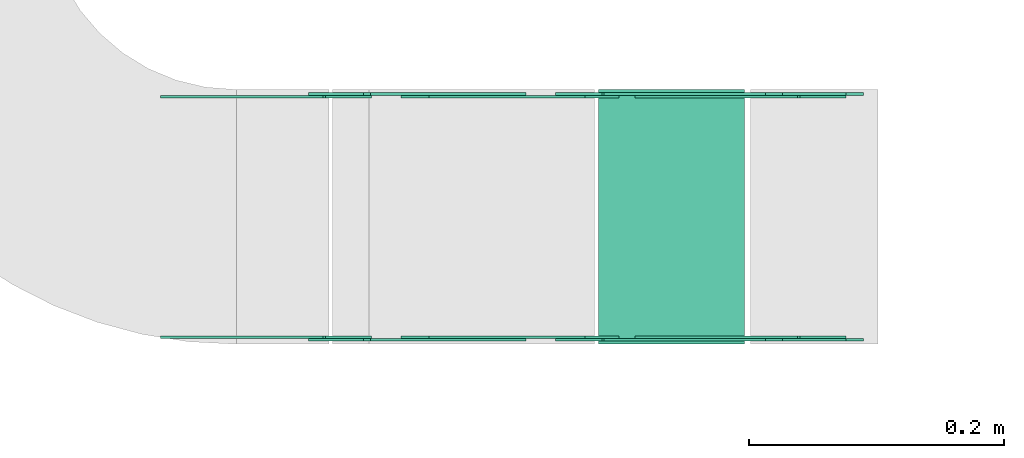
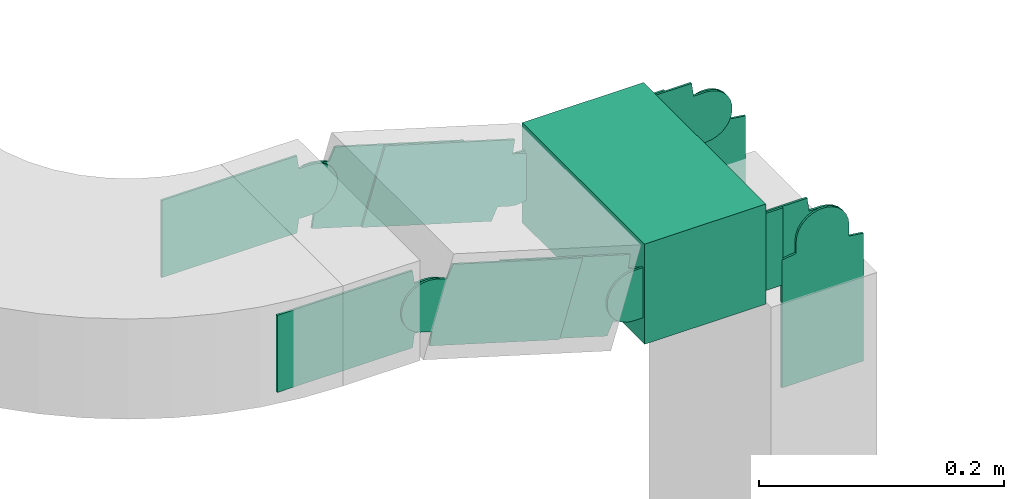
# One storey, part 21 of 38: 12 flow fittings, 1 flow segment.
"""IFC2X3 building model written with IfcOpenShell, lengths in millimetres."""

from ifc_helpers import new_model, entity, si_unit, converted_unit, derived_unit, direction, frame, frame_2d, origin, place, context, subcontext, project, spatial, polyline, circle_curve, parameter, trimmed, segment, composite_curve, rectangle, outline, extrude, source, transform, mapped, material, type_object, type_shapes, element, save


model = new_model("IFC2X3")

# Units and contexts
model_context = context("Model", 3, precision=0.01, world=origin(), true_north=direction((6.12303176911189e-17, 1.0)))
body_context = subcontext(model_context, "Body", "Model", "MODEL_VIEW")
ifc_project = project(units=[si_unit("LENGTHUNIT", "METRE", prefix="MILLI"), si_unit("AREAUNIT", "SQUARE_METRE"), si_unit("VOLUMEUNIT", "CUBIC_METRE"), converted_unit("PLANEANGLEUNIT", "DEGREE", entity("IfcRatioMeasure", 0.0174532925199433), si_unit("PLANEANGLEUNIT", "RADIAN"), dimensions=[0, 0, 0, 0, 0, 0, 0]), si_unit("MASSUNIT", "GRAM", prefix="KILO"), derived_unit("MASSDENSITYUNIT", [(si_unit("MASSUNIT", "GRAM", prefix="KILO"), 1), (si_unit("LENGTHUNIT", "METRE"), -3)]), derived_unit("MOMENTOFINERTIAUNIT", [(si_unit("LENGTHUNIT", "METRE"), 4)]), si_unit("TIMEUNIT", "SECOND"), si_unit("FREQUENCYUNIT", "HERTZ"), si_unit("THERMODYNAMICTEMPERATUREUNIT", "DEGREE_CELSIUS"), derived_unit("THERMALTRANSMITTANCEUNIT", [(si_unit("MASSUNIT", "GRAM", prefix="KILO"), 1), (si_unit("THERMODYNAMICTEMPERATUREUNIT", "KELVIN"), -1), (si_unit("TIMEUNIT", "SECOND"), -3)]), derived_unit("VOLUMETRICFLOWRATEUNIT", [(si_unit("LENGTHUNIT", "METRE"), 3), (si_unit("TIMEUNIT", "SECOND"), -1)]), derived_unit("MASSFLOWRATEUNIT", [(si_unit("MASSUNIT", "GRAM", prefix="KILO"), 1), (si_unit("TIMEUNIT", "SECOND"), -1)]), derived_unit("ROTATIONALFREQUENCYUNIT", [(si_unit("TIMEUNIT", "SECOND"), -1)]), si_unit("ELECTRICCURRENTUNIT", "AMPERE"), si_unit("ELECTRICVOLTAGEUNIT", "VOLT"), si_unit("POWERUNIT", "WATT"), si_unit("FORCEUNIT", "NEWTON", prefix="KILO"), si_unit("ILLUMINANCEUNIT", "LUX"), si_unit("LUMINOUSFLUXUNIT", "LUMEN"), si_unit("LUMINOUSINTENSITYUNIT", "CANDELA"), derived_unit("USERDEFINED", [(si_unit("MASSUNIT", "GRAM", prefix="KILO"), -1), (si_unit("LENGTHUNIT", "METRE"), -2), (si_unit("TIMEUNIT", "SECOND"), 3), (si_unit("LUMINOUSFLUXUNIT", "LUMEN"), 1)]), derived_unit("LINEARVELOCITYUNIT", [(si_unit("LENGTHUNIT", "METRE"), 1), (si_unit("TIMEUNIT", "SECOND"), -1)]), si_unit("PRESSUREUNIT", "PASCAL"), derived_unit("USERDEFINED", [(si_unit("LENGTHUNIT", "METRE"), -2), (si_unit("MASSUNIT", "GRAM", prefix="KILO"), 1), (si_unit("TIMEUNIT", "SECOND"), -2)]), derived_unit("LINEARFORCEUNIT", [(si_unit("MASSUNIT", "GRAM", prefix="KILO"), 1), (si_unit("LENGTHUNIT", "METRE"), 1), (si_unit("TIMEUNIT", "SECOND"), -2), (si_unit("LENGTHUNIT", "METRE"), -1)]), derived_unit("PLANARFORCEUNIT", [(si_unit("MASSUNIT", "GRAM", prefix="KILO"), 1), (si_unit("LENGTHUNIT", "METRE"), 1), (si_unit("TIMEUNIT", "SECOND"), -2), (si_unit("LENGTHUNIT", "METRE"), -2)])], contexts=[model_context])

# Site, building, storey
site_placement = place(None, frame((0.0, -0.00077364408347762, 0.0)))
site = spatial("IfcSite", under=ifc_project, at=site_placement, CompositionType="ELEMENT")
building_placement = place(site_placement, origin())
building = spatial("IfcBuilding", under=site, at=building_placement, CompositionType="ELEMENT")
storey_placement = place(building_placement, frame((0.0, 0.0, 4200.0)))
storey = spatial("IfcBuildingStorey", under=building, at=storey_placement, CompositionType="ELEMENT", Elevation=4200.0)

# Flow segment
cable_carrier_segment_type = type_object("IfcCableCarrierSegmentType", PredefinedType="CABLETRAYSEGMENT")
flow_segment_placement = place(storey_placement, frame((27566.6852011404, 7525.00077377346, 2871.96103583828)))
element("IfcFlowSegment", 1, at=flow_segment_placement, inside=storey, type_object=cable_carrier_segment_type, context=body_context, shape_type="SweptSolid", body=[
    extrude(rectangle(XDim=114.530349824433, YDim=200.0, at=frame_2d((2.16360263038951e-12, 0.0), x_axis=(1.0, 0.0))), frame((57.2651749122099, 100.0, 0.0)), (0.0, 0.0, 1.0), 99.9999999999989),
])

# Flow fittings
ifc_material = material(Name="G")
cable_carrier_fitting_type_1 = type_object("IfcCableCarrierFittingType", PredefinedType="NOTDEFINED", material=ifc_material)
shared_shape_1 = source(origin(), body_context, "Body", "SweptSolid", [
    extrude(outline(composite_curve([segment(trimmed(circle_curve(frame_2d((-41.4651162790697, 0.0), x_axis=(1.0, 0.0)), 25.0), [parameter(90.0000000000007)], [parameter(270.0)], True, "PARAMETER"), True, "CONTINUOUS"), segment(polyline([(-41.4651162790697, -25.0), (-29.9651162790697, -25.0)]), True, "CONTINUOUS"), segment(polyline([(-29.9651162790697, -25.0), (-28.1046511627907, -38.5)]), True, "CONTINUOUS"), segment(polyline([(-28.1046511627907, -38.5), (99.5348837209303, -38.5)]), True, "CONTINUOUS"), segment(polyline([(99.5348837209303, -38.5), (99.5348837209303, 38.5)]), True, "CONTINUOUS"), segment(polyline([(99.5348837209303, 38.5), (-28.1046511627907, 38.5)]), True, "CONTINUOUS"), segment(polyline([(-28.1046511627907, 38.5), (-29.9651162790697, 25.0)]), True, "CONTINUOUS"), segment(polyline([(-29.9651162790697, 25.0), (-41.46511627907, 25.0)]), True, "CONTINUOUS")], self_intersect=False)), frame((41.4651162790697, 0.0, 0.0), z_axis=(0.0, 0.0, -1.0), x_axis=(1.0, 0.0, 0.0)), (0.0, 0.0, -1.0), 2.0),
])
type_shapes(cable_carrier_fitting_type_1, [shared_shape_1])
for number, where, z_axis, x_axis in (
    (2, (27363.7155509645, 7720.46077378362, 2980.0), (0.0, 1.0, 0.0), (0.958072371883613, 0.0, -0.286526316825012)),
    (3, (27557.7833373836, 7529.5407737633, 2921.96103583827), (0.0, -1.0, 0.0), (1.0, 0.0, 0.0)),
    (4, (27736.2155509648, 7720.46077378362, 2921.96103583827), (0.0, 1.0, 0.0), (0.0, 0.0, -1.0)),
):
    element("IfcFlowFitting", number, at=place(storey_placement, frame(where, z_axis=z_axis, x_axis=x_axis)), inside=storey, type_object=cable_carrier_fitting_type_1, material=ifc_material, context=body_context, shape_type="MappedRepresentation", body=[
        mapped(shared_shape_1, transform((0.0, 0.0, 0.0), scale=1.0)),
    ])
cable_carrier_fitting_type_2 = type_object("IfcCableCarrierFittingType", PredefinedType="NOTDEFINED", material=ifc_material)
shared_shape_2 = source(origin(), body_context, "Body", "SweptSolid", [
    extrude(outline(composite_curve([segment(trimmed(circle_curve(frame_2d((-41.4651162790697, 0.0), x_axis=(1.0, 0.0)), 25.0), [parameter(90.0000000000007)], [parameter(270.0)], True, "PARAMETER"), True, "CONTINUOUS"), segment(polyline([(-41.4651162790697, -25.0), (-29.9651162790697, -25.0)]), True, "CONTINUOUS"), segment(polyline([(-29.9651162790697, -25.0), (-28.1046511627907, -38.5)]), True, "CONTINUOUS"), segment(polyline([(-28.1046511627907, -38.5), (99.5348837209303, -38.5)]), True, "CONTINUOUS"), segment(polyline([(99.5348837209303, -38.5), (99.5348837209303, 38.5)]), True, "CONTINUOUS"), segment(polyline([(99.5348837209303, 38.5), (-28.1046511627907, 38.5)]), True, "CONTINUOUS"), segment(polyline([(-28.1046511627907, 38.5), (-29.9651162790697, 25.0)]), True, "CONTINUOUS"), segment(polyline([(-29.9651162790697, 25.0), (-41.46511627907, 25.0)]), True, "CONTINUOUS")], self_intersect=False)), frame((41.4651162790697, 0.0, 0.0)), (0.0, 0.0, 1.0), 2.0),
])
type_shapes(cable_carrier_fitting_type_2, [shared_shape_2])
for number, where, z_axis, x_axis in (
    (5, (27363.7155509645, 7529.5407737633, 2980.0), (0.0, -1.0, 0.0), (0.958072371883613, 0.0, -0.286526316825012)),
    (6, (27557.7833373836, 7720.46077378362, 2921.96103583827), (0.0, 1.0, 0.0), (1.0, 0.0, 0.0)),
    (7, (27736.2155509648, 7529.5407737633, 2921.96103583827), (0.0, -1.0, 0.0), (0.0, 0.0, -1.0)),
):
    element("IfcFlowFitting", number, at=place(storey_placement, frame(where, z_axis=z_axis, x_axis=x_axis)), inside=storey, type_object=cable_carrier_fitting_type_2, material=ifc_material, context=body_context, shape_type="MappedRepresentation", body=[
        mapped(shared_shape_2, transform((0.0, 0.0, 0.0), scale=1.0)),
    ])
cable_carrier_fitting_type_3 = type_object("IfcCableCarrierFittingType", PredefinedType="NOTDEFINED", material=ifc_material)
shared_shape_3 = source(origin(), body_context, "Body", "SweptSolid", [
    extrude(outline(composite_curve([segment(trimmed(circle_curve(frame_2d((-41.4651162790697, 0.0), x_axis=(1.0, 0.0)), 25.0), [parameter(90.0000000000007)], [parameter(270.0)], True, "PARAMETER"), True, "CONTINUOUS"), segment(polyline([(-41.4651162790697, -25.0), (-29.9651162790697, -25.0)]), True, "CONTINUOUS"), segment(polyline([(-29.9651162790697, -25.0), (-28.1046511627907, -38.5)]), True, "CONTINUOUS"), segment(polyline([(-28.1046511627907, -38.5), (99.5348837209303, -38.5)]), True, "CONTINUOUS"), segment(polyline([(99.5348837209303, -38.5), (99.5348837209303, 38.5)]), True, "CONTINUOUS"), segment(polyline([(99.5348837209303, 38.5), (-28.1046511627907, 38.5)]), True, "CONTINUOUS"), segment(polyline([(-28.1046511627907, 38.5), (-29.9651162790697, 25.0)]), True, "CONTINUOUS"), segment(polyline([(-29.9651162790697, 25.0), (-41.46511627907, 25.0)]), True, "CONTINUOUS")], self_intersect=False)), frame((41.4651162790697, 0.0, 0.0), z_axis=(0.0, 0.0, -1.0), x_axis=(1.0, 0.0, 0.0)), (0.0, 0.0, -1.0), 2.0),
])
type_shapes(cable_carrier_fitting_type_3, [shared_shape_3])
for number, where, z_axis, x_axis in (
    (8, (27363.7155509645, 7531.5407737633, 2980.0), (0.0, -1.0, 0.0), (-1.0, 0.0, 0.0)),
    (9, (27557.7833373836, 7718.46077378361, 2921.96103583827), (0.0, 1.0, 0.0), (-0.958072371883606, 0.0, 0.286526316825037)),
    (10, (27736.2155509648, 7531.5407737633, 2921.96103583829), (0.0, -1.0, 0.0), (-1.0, 0.0, 0.0)),
):
    element("IfcFlowFitting", number, at=place(storey_placement, frame(where, z_axis=z_axis, x_axis=x_axis)), inside=storey, type_object=cable_carrier_fitting_type_3, material=ifc_material, context=body_context, shape_type="MappedRepresentation", body=[
        mapped(shared_shape_3, transform((0.0, 0.0, 0.0), scale=1.0)),
    ])
cable_carrier_fitting_type_4 = type_object("IfcCableCarrierFittingType", PredefinedType="NOTDEFINED", material=ifc_material)
shared_shape_4 = source(origin(), body_context, "Body", "SweptSolid", [
    extrude(outline(composite_curve([segment(trimmed(circle_curve(frame_2d((-41.4651162790697, 0.0), x_axis=(1.0, 0.0)), 25.0), [parameter(90.0000000000007)], [parameter(270.0)], True, "PARAMETER"), True, "CONTINUOUS"), segment(polyline([(-41.4651162790697, -25.0), (-29.9651162790697, -25.0)]), True, "CONTINUOUS"), segment(polyline([(-29.9651162790697, -25.0), (-28.1046511627907, -38.5)]), True, "CONTINUOUS"), segment(polyline([(-28.1046511627907, -38.5), (99.5348837209303, -38.5)]), True, "CONTINUOUS"), segment(polyline([(99.5348837209303, -38.5), (99.5348837209303, 38.5)]), True, "CONTINUOUS"), segment(polyline([(99.5348837209303, 38.5), (-28.1046511627907, 38.5)]), True, "CONTINUOUS"), segment(polyline([(-28.1046511627907, 38.5), (-29.9651162790697, 25.0)]), True, "CONTINUOUS"), segment(polyline([(-29.9651162790697, 25.0), (-41.46511627907, 25.0)]), True, "CONTINUOUS")], self_intersect=False)), frame((41.4651162790697, 0.0, 0.0)), (0.0, 0.0, 1.0), 2.0),
])
type_shapes(cable_carrier_fitting_type_4, [shared_shape_4])
for number, where, z_axis, x_axis in (
    (11, (27363.7155509645, 7718.46077378361, 2980.0), (0.0, 1.0, 0.0), (-1.0, 0.0, 0.0)),
    (12, (27557.7833373836, 7531.5407737633, 2921.96103583827), (0.0, -1.0, 0.0), (-0.958072371883606, 0.0, 0.286526316825037)),
    (13, (27736.2155509648, 7718.46077378361, 2921.96103583829), (0.0, 1.0, 0.0), (-1.0, 0.0, 0.0)),
):
    element("IfcFlowFitting", number, at=place(storey_placement, frame(where, z_axis=z_axis, x_axis=x_axis)), inside=storey, type_object=cable_carrier_fitting_type_4, material=ifc_material, context=body_context, shape_type="MappedRepresentation", body=[
        mapped(shared_shape_4, transform((0.0, 0.0, 0.0), scale=1.0)),
    ])

save(model, "model.ifc")
